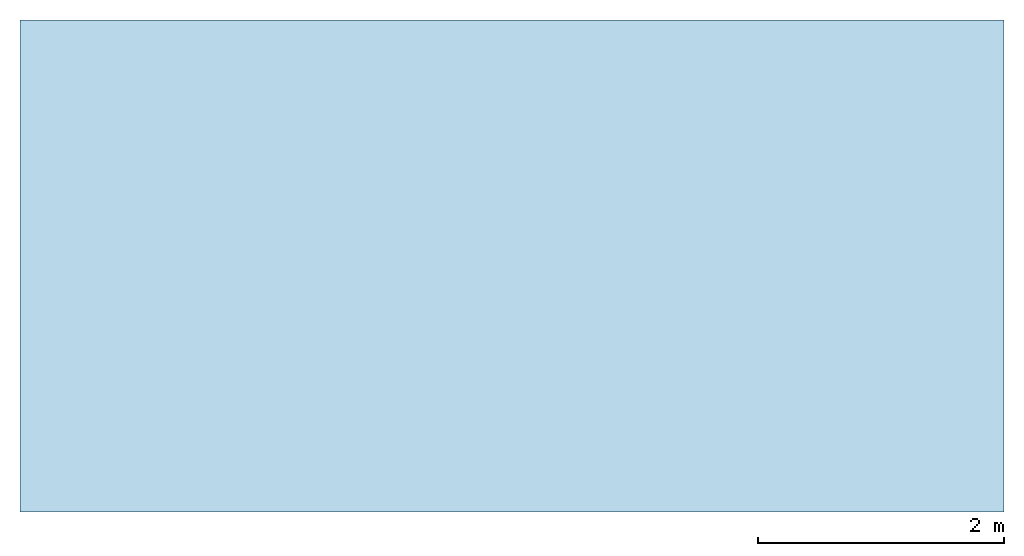
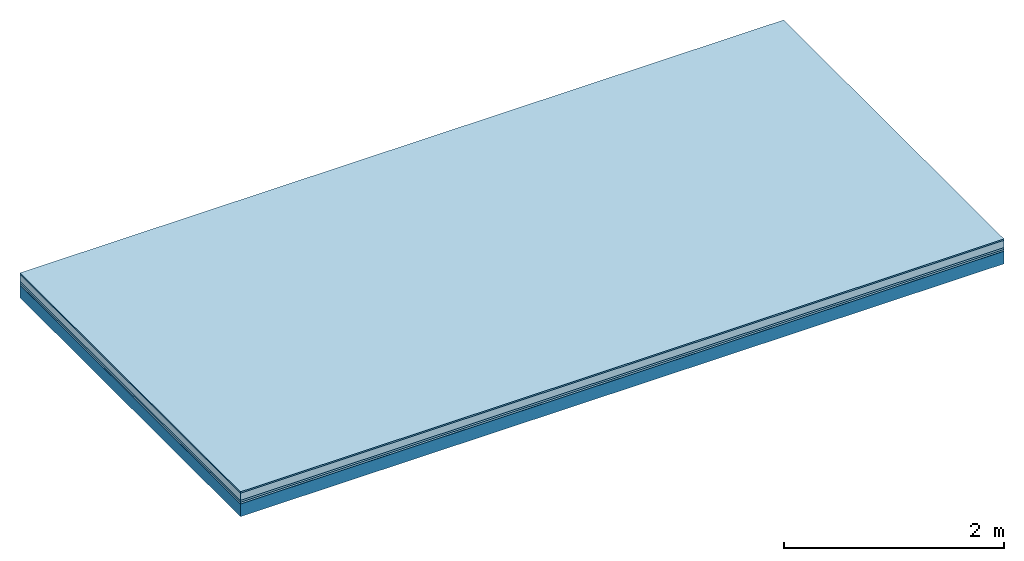
# One storey: 5 plates, 1 member, 1 element without a shape of its own.
"""IFC4 building model written with IfcOpenShell, lengths in metres."""

from ifc_helpers import new_model, si_unit, derived_unit, direction, frame, frame_2d, origin, origin_with_axes, place, context, project, spatial, rectangle, extrude, material, layer, layer_set, type_object, element, aggregate, save


model = new_model("IFC4")

# Units and contexts
plan_context = context("Plan", 3, precision=1e-05, world=origin(), true_north=direction((0.0, 1.0)))
model_context = context("Model", 3, precision=1e-05, world=origin(), true_north=direction((0.0, 1.0)))
ifc_project = project(units=[si_unit("LENGTHUNIT", "METRE"), derived_unit("SOUNDPRESSUREUNIT", [(si_unit("PRESSUREUNIT", "PASCAL", prefix="MICRO"), 0)]), si_unit("ENERGYUNIT", "JOULE", prefix="MEGA"), si_unit("MASSUNIT", "GRAM", prefix="KILO"), derived_unit("THERMALTRANSMITTANCEUNIT", [(si_unit("POWERUNIT", "WATT"), 1), (si_unit("AREAUNIT", "SQUARE_METRE"), -1), (si_unit("THERMODYNAMICTEMPERATUREUNIT", "KELVIN"), -1)]), derived_unit("AREADENSITYUNIT", [(si_unit("MASSUNIT", "GRAM", prefix="KILO"), 1), (si_unit("AREAUNIT", "SQUARE_METRE"), -1)]), derived_unit("USERDEFINED", [(si_unit("ENERGYUNIT", "JOULE", prefix="MEGA"), 1), (si_unit("AREAUNIT", "SQUARE_METRE"), -1)])], contexts=[plan_context, model_context])

# Site, building, storey
site = spatial("IfcSite", under=ifc_project)
building_placement = place(None, origin())
building = spatial("IfcBuilding", under=site, at=building_placement)
storey_placement = place(building_placement, origin())
storey = spatial("IfcBuildingStorey", under=building, at=storey_placement)

# Slab, member, plates
ifc_material_1 = material(Category="11.013")
ifc_layer_1 = layer(ifc_material_1, 0.015, Name="Flooring")
ifc_material_2 = material(Name="Cement screed", Category="04.006")
ifc_layer_2 = layer(ifc_material_2, 0.08, Name="On-material")
ifc_material_3 = material(Name="Wood fiber generic product", Category="10.009")
ifc_layer_3 = layer(ifc_material_3, 0.02, Name="Impact sound insulation")
ifc_material_4 = material()
ifc_layer_4 = layer(ifc_material_4, 0.02, Name="Additional insulation")
ifc_material_5 = material(Name="protection", Category="09.007")
ifc_layer_5 = layer(ifc_material_5, 0.0005, Name="Sub-floor")
ifc_material_6 = material(Name="no composite action")
ifc_layer_6 = layer(ifc_material_6, 0.0, Name="Bond")
ifc_layer_7 = layer(None, 0.14, Name="Supporting structure")
ifc_layer_set = layer_set([ifc_layer_1, ifc_layer_2, ifc_layer_3, ifc_layer_4, ifc_layer_5, ifc_layer_6, ifc_layer_7])
slab_type = type_object("IfcSlabType", Name="A2070", PredefinedType="NOTDEFINED", material=ifc_layer_set)
slab_placement = place(None, frame((0.0, 0.0, 0.0), z_axis=(0.0, 0.0, -1.0), x_axis=(1.0, 0.0, 0.0)))
slab = element("IfcSlab", 1, at=slab_placement, inside=storey, type_object=slab_type, material=ifc_layer_set, Name="Slab #1")
ifc_material_7 = material(Name="Solid timber panel")
member_placement = place(slab_placement, origin())
member = element("IfcMember", 2, at=member_placement, material=ifc_material_7, Name="Supporting structure", context=plan_context, shape_type="SweptSolid", body=[
    extrude(rectangle(XDim=1.0, YDim=0.14, at=frame_2d((0.5, 0.07), x_axis=(1.0, 0.0))), frame((0.0, 4.0, 0.1355), z_axis=(0.0, -1.0, 0.0), x_axis=(1.0, 0.0, 0.0)), (0.0, 0.0, 1.0), 4.0),
    extrude(rectangle(XDim=1.0, YDim=0.14, at=frame_2d((0.5, 0.07), x_axis=(1.0, 0.0))), frame((1.0, 4.0, 0.1355), z_axis=(0.0, -1.0, 0.0), x_axis=(1.0, 0.0, 0.0)), (0.0, 0.0, 1.0), 4.0),
    extrude(rectangle(XDim=1.0, YDim=0.14, at=frame_2d((0.5, 0.07), x_axis=(1.0, 0.0))), frame((2.0, 4.0, 0.1355), z_axis=(0.0, -1.0, 0.0), x_axis=(1.0, 0.0, 0.0)), (0.0, 0.0, 1.0), 4.0),
    extrude(rectangle(XDim=1.0, YDim=0.14, at=frame_2d((0.5, 0.07), x_axis=(1.0, 0.0))), frame((3.0, 4.0, 0.1355), z_axis=(0.0, -1.0, 0.0), x_axis=(1.0, 0.0, 0.0)), (0.0, 0.0, 1.0), 4.0),
    extrude(rectangle(XDim=1.0, YDim=0.14, at=frame_2d((0.5, 0.07), x_axis=(1.0, 0.0))), frame((4.0, 4.0, 0.1355), z_axis=(0.0, -1.0, 0.0), x_axis=(1.0, 0.0, 0.0)), (0.0, 0.0, 1.0), 4.0),
    extrude(rectangle(XDim=1.0, YDim=0.14, at=frame_2d((0.5, 0.07), x_axis=(1.0, 0.0))), frame((5.0, 4.0, 0.1355), z_axis=(0.0, -1.0, 0.0), x_axis=(1.0, 0.0, 0.0)), (0.0, 0.0, 1.0), 4.0),
    extrude(rectangle(XDim=1.0, YDim=0.14, at=frame_2d((0.5, 0.07), x_axis=(1.0, 0.0))), frame((6.0, 4.0, 0.1355), z_axis=(0.0, -1.0, 0.0), x_axis=(1.0, 0.0, 0.0)), (0.0, 0.0, 1.0), 4.0),
    extrude(rectangle(XDim=1.0, YDim=0.14, at=frame_2d((0.5, 0.07), x_axis=(1.0, 0.0))), frame((7.0, 4.0, 0.1355), z_axis=(0.0, -1.0, 0.0), x_axis=(1.0, 0.0, 0.0)), (0.0, 0.0, 1.0), 4.0),
])
plate_1_placement = place(slab_placement, origin())
plate_1 = element("IfcPlate", 3, at=plate_1_placement, material=ifc_material_1, Name="Flooring", context=plan_context, shape_type="SweptSolid", body=[
    extrude(rectangle(XDim=8.0, YDim=4.0, at=frame_2d((4.0, 2.0), x_axis=(1.0, 0.0))), origin_with_axes(), (0.0, 0.0, 1.0), 0.015),
])
plate_2_placement = place(slab_placement, origin())
plate_2 = element("IfcPlate", 4, at=plate_2_placement, material=ifc_material_2, Name="On-material", context=plan_context, shape_type="SweptSolid", body=[
    extrude(rectangle(XDim=8.0, YDim=4.0, at=frame_2d((4.0, 2.0), x_axis=(1.0, 0.0))), frame((0.0, 0.0, 0.015), z_axis=(0.0, 0.0, 1.0), x_axis=(1.0, 0.0, 0.0)), (0.0, 0.0, 1.0), 0.08),
])
plate_3_placement = place(slab_placement, origin())
plate_3 = element("IfcPlate", 5, at=plate_3_placement, material=ifc_material_3, Name="Impact sound insulation", context=plan_context, shape_type="SweptSolid", body=[
    extrude(rectangle(XDim=8.0, YDim=4.0, at=frame_2d((4.0, 2.0), x_axis=(1.0, 0.0))), frame((0.0, 0.0, 0.095), z_axis=(0.0, 0.0, 1.0), x_axis=(1.0, 0.0, 0.0)), (0.0, 0.0, 1.0), 0.02),
])
plate_4_placement = place(slab_placement, origin())
plate_4 = element("IfcPlate", 6, at=plate_4_placement, material=ifc_material_4, Name="Additional insulation", context=plan_context, shape_type="SweptSolid", body=[
    extrude(rectangle(XDim=8.0, YDim=4.0, at=frame_2d((4.0, 2.0), x_axis=(1.0, 0.0))), frame((0.0, 0.0, 0.115), z_axis=(0.0, 0.0, 1.0), x_axis=(1.0, 0.0, 0.0)), (0.0, 0.0, 1.0), 0.02),
])
plate_5_placement = place(slab_placement, origin())
plate_5 = element("IfcPlate", 7, at=plate_5_placement, material=ifc_material_5, Name="Sub-floor", context=plan_context, shape_type="SweptSolid", body=[
    extrude(rectangle(XDim=8.0, YDim=4.0, at=frame_2d((4.0, 2.0), x_axis=(1.0, 0.0))), frame((0.0, 0.0, 0.135), z_axis=(0.0, 0.0, 1.0), x_axis=(1.0, 0.0, 0.0)), (0.0, 0.0, 1.0), 0.0005),
])
aggregate(slab, [plate_1, plate_2, plate_3, plate_4, plate_5, member])

save(model, "model.ifc")
